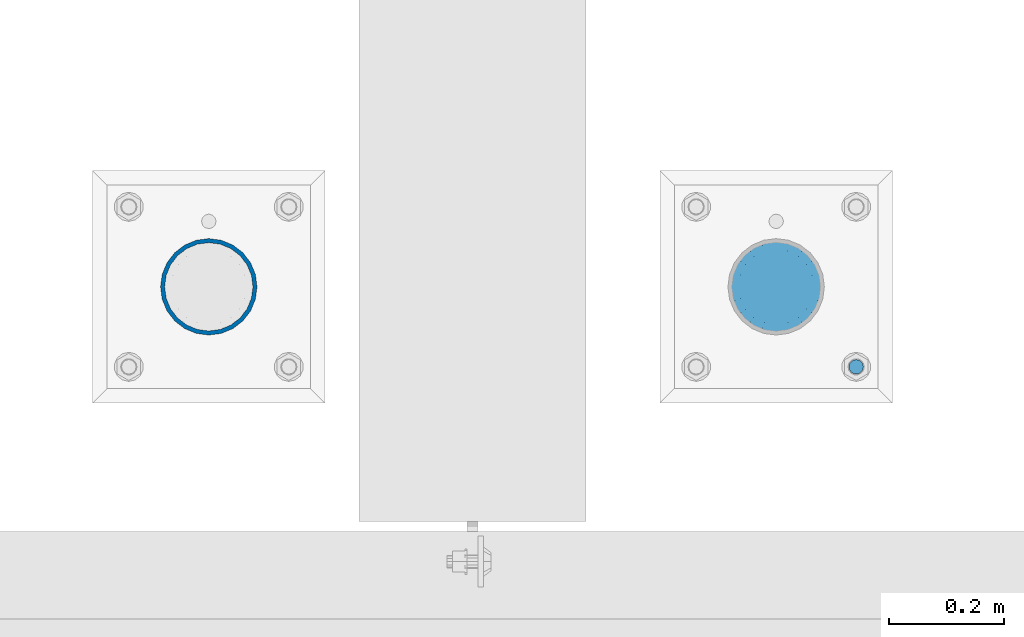
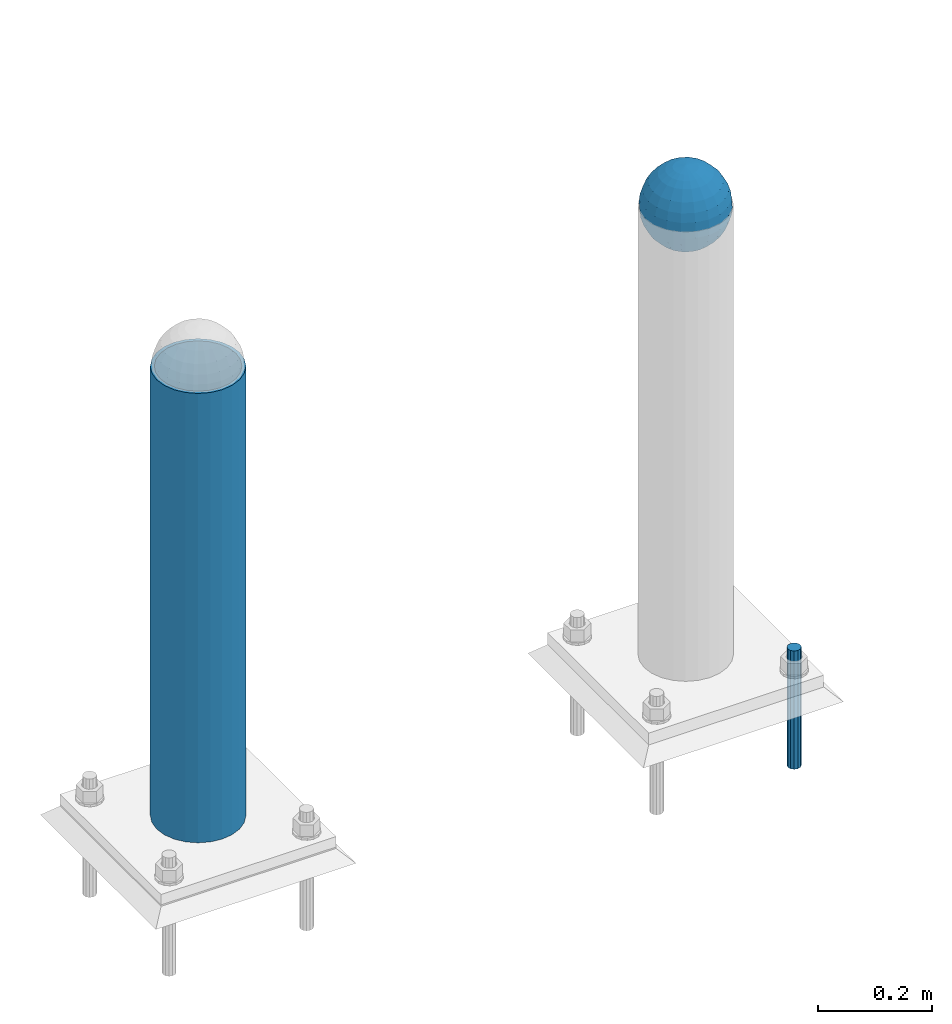
# One storey, part 1440 of 3843: 3 columns, 3 elements without a shape of their own.
"""IFC2X3 building model written with IfcOpenShell, lengths in millimetres."""

from ifc_helpers import new_model, si_unit, frame, origin_with_axes, place, context, subcontext, project, spatial, faceted_brep, material, type_object, element, aggregate, save


model = new_model("IFC2X3")

# Units and contexts
model_context = context("Model", 3, precision=1e-05, world=origin_with_axes())
body_context = subcontext(model_context, "Body", "Model", "MODEL_VIEW")
ifc_project = project(units=[si_unit("LENGTHUNIT", "METRE", prefix="MILLI"), si_unit("AREAUNIT", "SQUARE_METRE"), si_unit("VOLUMEUNIT", "CUBIC_METRE"), si_unit("MASSUNIT", "GRAM", prefix="KILO"), si_unit("TIMEUNIT", "SECOND"), si_unit("PLANEANGLEUNIT", "RADIAN"), si_unit("SOLIDANGLEUNIT", "STERADIAN"), si_unit("THERMODYNAMICTEMPERATUREUNIT", "DEGREE_CELSIUS"), si_unit("LUMINOUSINTENSITYUNIT", "LUMEN")], contexts=[model_context])

# Site, building, storey
site_placement = place(None, origin_with_axes())
site = spatial("IfcSite", under=ifc_project, at=site_placement, CompositionType="ELEMENT")
building_placement = place(site_placement, origin_with_axes())
building = spatial("IfcBuilding", under=site, at=building_placement, Name="Undefined", CompositionType="ELEMENT")
storey_placement = place(building_placement, origin_with_axes())
storey = spatial("IfcBuildingStorey", under=building, at=storey_placement, Name="Undefined", CompositionType="ELEMENT", Elevation=0.0)

# Assembly, column
assembly_1_placement = place(storey_placement, origin_with_axes())
assembly_1 = element("IfcElementAssembly", 1, at=assembly_1_placement, inside=storey, Name="CONC. FILL", AssemblyPlace="NOTDEFINED", PredefinedType="REINFORCEMENT_UNIT")
ifc_material_1 = material(Name="CONCRETE/1500")
column_type_1 = type_object("IfcColumnType", PredefinedType="NOTDEFINED")
column_1_placement = place(assembly_1_placement, frame((37106.2721557617, 11565.3447954918, 31411.8625), z_axis=(-1.0, 0.0, 0.0), x_axis=(0.0, 0.0, 1.0)))
column_1 = element("IfcColumn", 2, at=column_1_placement, type_object=column_type_1, material=ifc_material_1, Name="CONC. FILL", context=body_context, shape_type="Brep", body=[
    faceted_brep([(0.0, 0.0, 2.0), (0.0, -0.619999999995343, 1.89999999999964), (3.36549999999988, -7.1422259999963, 21.9814139999999), (3.36549999999988, 0.0, 23.1139999999996), (0.0, -1.17999999999302, 1.6200000000008), (3.36549999999988, -13.5910319999966, 18.6992260000006), (0.0, -1.61999999999534, 1.18000000000029), (3.36549999999988, -18.699225999997, 13.5910320000003), (0.0, -1.89999999999418, 0.6200000000008), (3.36549999999988, -21.9814139999944, 7.14222599999994), (0.0, -2.0, 0.0), (3.36549999999988, -23.1140000000014, 0.0), (0.0, -1.89999999999418, -0.6200000000008), (3.36549999999988, -21.9814139999944, -7.14222599999994), (0.0, -1.61999999999534, -1.18000000000029), (3.36549999999988, -18.699225999997, -13.5910320000003), (0.0, -1.17999999999302, -1.6200000000008), (3.36549999999988, -13.5910319999966, -18.6992260000006), (0.0, -0.619999999995343, -1.89999999999964), (3.36549999999988, -7.1422259999963, -21.9814139999999), (0.0, 0.0, -2.0), (3.36549999999988, 0.0, -23.1139999999996), (0.0, 0.619999999995343, -1.89999999999964), (3.36549999999988, 7.1422259999963, -21.9814139999999), (0.0, 1.17999999999302, -1.6200000000008), (3.36549999999988, 13.5910319999966, -18.6992260000006), (0.0, 1.61999999999534, -1.18000000000029), (3.36549999999988, 18.699225999997, -13.5910320000003), (0.0, 1.89999999999418, -0.6200000000008), (3.36549999999988, 21.9814139999944, -7.14222599999994), (0.0, 2.0, 0.0), (3.36549999999988, 23.1140000000014, 0.0), (0.0, 1.89999999999418, 0.6200000000008), (3.36549999999988, 21.9814139999944, 7.14222599999994), (0.0, 1.61999999999534, 1.18000000000029), (3.36549999999988, 18.699225999997, 13.5910320000003), (0.0, 1.17999999999302, 1.6200000000008), (3.36549999999988, 13.5910319999966, 18.6992260000006), (0.0, 0.619999999995343, 1.89999999999964), (3.36549999999988, 7.1422259999963, 21.9814139999999), (8.41374999999971, -11.1214661999984, 34.2282018000005), (8.41374999999971, 0.0, 35.9917999999998), (8.41374999999971, -21.1631784000056, 29.1173662000001), (8.41374999999971, -29.1173661999928, 21.1631784000001), (8.41374999999971, -34.2282017999969, 11.1214662000002), (8.41374999999971, -35.9918000000034, 0.0), (8.41374999999971, -34.2282017999969, -11.1214662000002), (8.41374999999971, -29.1173661999928, -21.1631784000001), (8.41374999999971, -21.1631784000056, -29.1173662000001), (8.41374999999971, -11.1214661999984, -34.2282018000005), (8.41374999999971, 0.0, -35.9917999999998), (8.41374999999971, 11.1214661999984, -34.2282018000005), (8.41374999999971, 21.1631784000056, -29.1173662000001), (8.41374999999971, 29.1173661999928, -21.1631784000001), (8.41374999999971, 34.2282017999969, -11.1214662000002), (8.41374999999971, 35.9918000000034, 0.0), (8.41374999999971, 34.2282017999969, 11.1214662000002), (8.41374999999971, 29.1173661999928, 21.1631784000001), (8.41374999999971, 21.1631784000056, 29.1173662000001), (8.41374999999971, 11.1214661999984, 34.2282018000005), (16.8274999999994, -15.3047700000025, 47.1030300000002), (16.8274999999994, 0.0, 49.5300000000007), (16.8274999999994, -29.1236400000053, 40.0697700000001), (16.8274999999994, -40.0697700000019, 29.1236399999998), (16.8274999999994, -47.1030299999984, 15.3047700000006), (16.8274999999994, -49.5299999999988, 0.0), (16.8274999999994, -47.1030299999984, -15.3047700000006), (16.8274999999994, -40.0697700000019, -29.1236399999998), (16.8274999999994, -29.1236400000053, -40.0697700000001), (16.8274999999994, -15.3047700000025, -47.1030300000002), (16.8274999999994, 0.0, -49.5300000000007), (16.8274999999994, 15.3047700000025, -47.1030300000002), (16.8274999999994, 29.1236400000053, -40.0697700000001), (16.8274999999994, 40.0697700000019, -29.1236399999998), (16.8274999999994, 47.1030299999984, -15.3047700000006), (16.8274999999994, 49.5299999999988, 0.0), (16.8274999999994, 47.1030299999984, 15.3047700000006), (16.8274999999994, 40.0697700000019, 29.1236399999998), (16.8274999999994, 29.1236400000053, 40.0697700000001), (16.8274999999994, 15.3047700000025, 47.1030300000002), (33.6549999999988, -20.4063599999936, 62.8040400000009), (33.6549999999988, 0.0, 66.0400000000009), (33.6549999999988, -38.831520000007, 53.4263599999995), (33.6549999999988, -53.4263599999977, 38.8315199999997), (33.6549999999988, -62.8040400000027, 20.4063600000009), (33.6549999999988, -66.0399999999936, 0.0), (33.6549999999988, -62.8040400000027, -20.4063600000009), (33.6549999999988, -53.4263599999977, -38.8315199999997), (33.6549999999988, -38.831520000007, -53.4263599999995), (33.6549999999988, -20.4063599999936, -62.8040400000009), (33.6549999999988, 0.0, -66.0400000000009), (33.6549999999988, 20.4063599999936, -62.8040400000009), (33.6549999999988, 38.831520000007, -53.4263599999995), (33.6549999999988, 53.4263599999977, -38.8315199999997), (33.6549999999988, 62.8040400000027, -20.4063600000009), (33.6549999999988, 66.0399999999936, 0.0), (33.6549999999988, 62.8040400000027, 20.4063600000009), (33.6549999999988, 53.4263599999977, 38.8315199999997), (33.6549999999988, 38.831520000007, 53.4263599999995), (33.6549999999988, 20.4063599999936, 62.8040400000009), (50.4824999999983, -23.3907901500061, 71.9891308499991), (50.4824999999983, 0.0, 75.6983500000006), (50.4824999999983, -44.5106298000028, 61.23996515), (50.4824999999983, -61.2399651500018, 44.5106297999992), (50.4824999999983, -71.9891308499937, 23.3907901500006), (50.4824999999983, -75.698350000006, 0.0), (50.4824999999983, -71.9891308499937, -23.3907901500006), (50.4824999999983, -61.2399651500018, -44.5106297999992), (50.4824999999983, -44.5106298000028, -61.23996515), (50.4824999999983, -23.3907901500061, -71.9891308499991), (50.4824999999983, 0.0, -75.6983500000006), (50.4824999999983, 23.3907901500061, -71.9891308499991), (50.4824999999983, 44.5106298000028, -61.23996515), (50.4824999999983, 61.2399651500018, -44.5106297999992), (50.4824999999983, 71.9891308499937, -23.3907901500006), (50.4824999999983, 75.698350000006, 0.0), (50.4824999999983, 71.9891308499937, 23.3907901500006), (50.4824999999983, 61.2399651500018, 44.5106297999992), (50.4824999999983, 44.5106298000028, 61.23996515), (50.4824999999983, 23.3907901500061, 71.9891308499991), (67.3099999999977, -24.9977910000016, 76.9349490000004), (67.3099999999977, 0.0, 80.8989999999994), (67.3099999999977, -47.5686120000028, 65.4472910000004), (67.3099999999977, -65.447291000004, 47.5686119999991), (67.3099999999977, -76.9349490000022, 24.9977909999998), (67.3099999999977, -80.8990000000049, 0.0), (67.3099999999977, -76.9349490000022, -24.9977909999998), (67.3099999999977, -65.447291000004, -47.5686119999991), (67.3099999999977, -47.5686120000028, -65.4472910000004), (67.3099999999977, -24.9977910000016, -76.9349490000004), (67.3099999999977, 0.0, -80.8989999999994), (67.3099999999977, 24.9977910000016, -76.9349490000004), (67.3099999999977, 47.5686120000028, -65.4472910000004), (67.3099999999977, 65.447291000004, -47.5686119999991), (67.3099999999977, 76.9349490000022, -24.9977909999998), (67.3099999999977, 80.8990000000049, 0.0), (67.3099999999977, 76.9349490000022, 24.9977909999998), (67.3099999999977, 65.447291000004, 47.5686119999991), (67.3099999999977, 47.5686120000028, 65.4472910000004), (67.3099999999977, 24.9977910000016, 76.9349490000004), (84.1374999999935, -25.5079499999993, 78.5050499999998), (84.1374999999935, 0.0, 82.5499999999993), (84.1374999999935, -48.5393999999942, 66.7829500000007), (84.1374999999935, -66.7829499999934, 48.5393999999997), (84.1374999999935, -78.505050000007, 25.5079499999993), (84.1374999999935, -82.5500000000029, 0.0), (84.1374999999935, -78.505050000007, -25.5079499999993), (84.1374999999935, -66.7829499999934, -48.5393999999997), (84.1374999999935, -48.5393999999942, -66.7829500000007), (84.1374999999935, -25.5079499999993, -78.5050499999998), (84.1374999999935, 0.0, -82.5499999999993), (84.1374999999935, 25.5079499999993, -78.5050499999998), (84.1374999999935, 48.5393999999942, -66.7829500000007), (84.1374999999935, 66.7829499999934, -48.5393999999997), (84.1374999999935, 78.505050000007, -25.5079499999993), (84.1374999999935, 82.5500000000029, 0.0), (84.1374999999935, 78.505050000007, 25.5079499999993), (84.1374999999935, 66.7829499999934, 48.5393999999997), (84.1374999999935, 48.5393999999942, 66.7829500000007), (84.1374999999935, 25.5079499999993, 78.5050499999998), (100.964999999993, -24.9977910000016, 76.9349490000004), (100.964999999993, 0.0, 80.8989999999994), (100.964999999993, -47.5686120000028, 65.4472910000004), (100.964999999993, -65.447291000004, 47.5686119999991), (100.964999999993, -76.9349490000022, 24.9977909999998), (100.964999999993, -80.8990000000049, 0.0), (100.964999999993, -76.9349490000022, -24.9977909999998), (100.964999999993, -65.447291000004, -47.5686119999991), (100.964999999993, -47.5686120000028, -65.4472910000004), (100.964999999993, -24.9977910000016, -76.9349490000004), (100.964999999993, 0.0, -80.8989999999994), (100.964999999993, 24.9977910000016, -76.9349490000004), (100.964999999993, 47.5686120000028, -65.4472910000004), (100.964999999993, 65.447291000004, -47.5686119999991), (100.964999999993, 76.9349490000022, -24.9977909999998), (100.964999999993, 80.8990000000049, 0.0), (100.964999999993, 76.9349490000022, 24.9977909999998), (100.964999999993, 65.447291000004, 47.5686119999991), (100.964999999993, 47.5686120000028, 65.4472910000004), (100.964999999993, 24.9977910000016, 76.9349490000004), (117.792499999992, -23.3907901500061, 71.9891308499991), (117.792499999992, 0.0, 75.6983500000006), (117.792499999992, -44.5106298000028, 61.23996515), (117.792499999992, -61.2399651500018, 44.5106297999992), (117.792499999992, -71.9891308499937, 23.3907901500006), (117.792499999992, -75.698350000006, 0.0), (117.792499999992, -71.9891308499937, -23.3907901500006), (117.792499999992, -61.2399651500018, -44.5106297999992), (117.792499999992, -44.5106298000028, -61.23996515), (117.792499999992, -23.3907901500061, -71.9891308499991), (117.792499999992, 0.0, -75.6983500000006), (117.792499999992, 23.3907901500061, -71.9891308499991), (117.792499999992, 44.5106298000028, -61.23996515), (117.792499999992, 61.2399651500018, -44.5106297999992), (117.792499999992, 71.9891308499937, -23.3907901500006), (117.792499999992, 75.698350000006, 0.0), (117.792499999992, 71.9891308499937, 23.3907901500006), (117.792499999992, 61.2399651500018, 44.5106297999992), (117.792499999992, 44.5106298000028, 61.23996515), (117.792499999992, 23.3907901500061, 71.9891308499991), (134.619999999992, -20.4063599999936, 62.8040400000009), (134.619999999992, 0.0, 66.0400000000009), (134.619999999992, -38.831520000007, 53.4263599999995), (134.619999999992, -53.4263599999977, 38.8315199999997), (134.619999999992, -62.8040400000027, 20.4063600000009), (134.619999999992, -66.0399999999936, 0.0), (134.619999999992, -62.8040400000027, -20.4063600000009), (134.619999999992, -53.4263599999977, -38.8315199999997), (134.619999999992, -38.831520000007, -53.4263599999995), (134.619999999992, -20.4063599999936, -62.8040400000009), (134.619999999992, 0.0, -66.0400000000009), (134.619999999992, 20.4063599999936, -62.8040400000009), (134.619999999992, 38.831520000007, -53.4263599999995), (134.619999999992, 53.4263599999977, -38.8315199999997), (134.619999999992, 62.8040400000027, -20.4063600000009), (134.619999999992, 66.0399999999936, 0.0), (134.619999999992, 62.8040400000027, 20.4063600000009), (134.619999999992, 53.4263599999977, 38.8315199999997), (134.619999999992, 38.831520000007, 53.4263599999995), (134.619999999992, 20.4063599999936, 62.8040400000009), (151.447499999991, -15.3047700000025, 47.1030300000002), (151.447499999991, 0.0, 49.5300000000007), (151.447499999991, -29.1236400000053, 40.0697700000001), (151.447499999991, -40.0697700000019, 29.1236399999998), (151.447499999991, -47.1030299999984, 15.3047700000006), (151.447499999991, -49.5299999999988, 0.0), (151.447499999991, -47.1030299999984, -15.3047700000006), (151.447499999991, -40.0697700000019, -29.1236399999998), (151.447499999991, -29.1236400000053, -40.0697700000001), (151.447499999991, -15.3047700000025, -47.1030300000002), (151.447499999991, 0.0, -49.5300000000007), (151.447499999991, 15.3047700000025, -47.1030300000002), (151.447499999991, 29.1236400000053, -40.0697700000001), (151.447499999991, 40.0697700000019, -29.1236399999998), (151.447499999991, 47.1030299999984, -15.3047700000006), (151.447499999991, 49.5299999999988, 0.0), (151.447499999991, 47.1030299999984, 15.3047700000006), (151.447499999991, 40.0697700000019, 29.1236399999998), (151.447499999991, 29.1236400000053, 40.0697700000001), (151.447499999991, 15.3047700000025, 47.1030300000002), (159.861249999991, -11.1214661999984, 34.2282018000005), (159.861249999991, 0.0, 35.9917999999998), (159.861249999991, -21.1631784000056, 29.1173662000001), (159.861249999991, -29.1173661999928, 21.1631784000001), (159.861249999991, -34.2282017999969, 11.1214662000002), (159.861249999991, -35.9918000000034, 0.0), (159.861249999991, -34.2282017999969, -11.1214662000002), (159.861249999991, -29.1173661999928, -21.1631784000001), (159.861249999991, -21.1631784000056, -29.1173662000001), (159.861249999991, -11.1214661999984, -34.2282018000005), (159.861249999991, 0.0, -35.9917999999998), (159.861249999991, 11.1214661999984, -34.2282018000005), (159.861249999991, 21.1631784000056, -29.1173662000001), (159.861249999991, 29.1173661999928, -21.1631784000001), (159.861249999991, 34.2282017999969, -11.1214662000002), (159.861249999991, 35.9918000000034, 0.0), (159.861249999991, 34.2282017999969, 11.1214662000002), (159.861249999991, 29.1173661999928, 21.1631784000001), (159.861249999991, 21.1631784000056, 29.1173662000001), (159.861249999991, 11.1214661999984, 34.2282018000005), (164.909499999991, -7.1422259999963, 21.9814139999999), (164.909499999991, 0.0, 23.1139999999996), (164.909499999991, -13.5910319999966, 18.6992260000006), (164.909499999991, -18.699225999997, 13.5910320000003), (164.909499999991, -21.9814139999944, 7.14222599999994), (164.909499999991, -23.1140000000014, 0.0), (164.909499999991, -21.9814139999944, -7.14222599999994), (164.909499999991, -18.699225999997, -13.5910320000003), (164.909499999991, -13.5910319999966, -18.6992260000006), (164.909499999991, -7.1422259999963, -21.9814139999999), (164.909499999991, 0.0, -23.1139999999996), (164.909499999991, 7.1422259999963, -21.9814139999999), (164.909499999991, 13.5910319999966, -18.6992260000006), (164.909499999991, 18.699225999997, -13.5910320000003), (164.909499999991, 21.9814139999944, -7.14222599999994), (164.909499999991, 23.1140000000014, 0.0), (164.909499999991, 21.9814139999944, 7.14222599999994), (164.909499999991, 18.699225999997, 13.5910320000003), (164.909499999991, 13.5910319999966, 18.6992260000006), (164.909499999991, 7.1422259999963, 21.9814139999999), (168.274999999991, -0.619999999995343, 1.89999999999964), (168.274999999991, 0.0, 2.0), (168.274999999991, -1.17999999999302, 1.6200000000008), (168.274999999991, -1.61999999999534, 1.18000000000029), (168.274999999991, -1.89999999999418, 0.6200000000008), (168.274999999991, -2.0, 0.0), (168.274999999991, -1.89999999999418, -0.6200000000008), (168.274999999991, -1.61999999999534, -1.18000000000029), (168.274999999991, -1.17999999999302, -1.6200000000008), (168.274999999991, -0.619999999995343, -1.89999999999964), (168.274999999991, 0.0, -2.0), (168.274999999991, 0.619999999995343, -1.89999999999964), (168.274999999991, 1.17999999999302, -1.6200000000008), (168.274999999991, 1.61999999999534, -1.18000000000029), (168.274999999991, 1.89999999999418, -0.6200000000008), (168.274999999991, 2.0, 0.0), (168.274999999991, 1.89999999999418, 0.6200000000008), (168.274999999991, 1.61999999999534, 1.18000000000029), (168.274999999991, 1.17999999999302, 1.6200000000008), (168.274999999991, 0.619999999995343, 1.89999999999964)], [[[0, 1, 2, 3]], [[1, 4, 5, 2]], [[4, 6, 7, 5]], [[6, 8, 9, 7]], [[8, 10, 11, 9]], [[10, 12, 13, 11]], [[12, 14, 15, 13]], [[14, 16, 17, 15]], [[16, 18, 19, 17]], [[18, 20, 21, 19]], [[20, 22, 23, 21]], [[22, 24, 25, 23]], [[24, 26, 27, 25]], [[26, 28, 29, 27]], [[28, 30, 31, 29]], [[30, 32, 33, 31]], [[32, 34, 35, 33]], [[34, 36, 37, 35]], [[36, 38, 39, 37]], [[38, 0, 3, 39]], [[38, 36, 34, 32, 30, 28, 26, 24, 22, 20, 18, 16, 14, 12, 10, 8, 6, 4, 1, 0]], [[3, 2, 40, 41]], [[2, 5, 42, 40]], [[5, 7, 43, 42]], [[7, 9, 44, 43]], [[9, 11, 45, 44]], [[11, 13, 46, 45]], [[13, 15, 47, 46]], [[15, 17, 48, 47]], [[17, 19, 49, 48]], [[19, 21, 50, 49]], [[21, 23, 51, 50]], [[23, 25, 52, 51]], [[25, 27, 53, 52]], [[27, 29, 54, 53]], [[29, 31, 55, 54]], [[31, 33, 56, 55]], [[33, 35, 57, 56]], [[35, 37, 58, 57]], [[37, 39, 59, 58]], [[39, 3, 41, 59]], [[41, 40, 60, 61]], [[40, 42, 62, 60]], [[42, 43, 63, 62]], [[43, 44, 64, 63]], [[44, 45, 65, 64]], [[45, 46, 66, 65]], [[46, 47, 67, 66]], [[47, 48, 68, 67]], [[48, 49, 69, 68]], [[49, 50, 70, 69]], [[50, 51, 71, 70]], [[51, 52, 72, 71]], [[52, 53, 73, 72]], [[53, 54, 74, 73]], [[54, 55, 75, 74]], [[55, 56, 76, 75]], [[56, 57, 77, 76]], [[57, 58, 78, 77]], [[58, 59, 79, 78]], [[59, 41, 61, 79]], [[61, 60, 80, 81]], [[60, 62, 82, 80]], [[62, 63, 83, 82]], [[63, 64, 84, 83]], [[64, 65, 85, 84]], [[65, 66, 86, 85]], [[66, 67, 87, 86]], [[67, 68, 88, 87]], [[68, 69, 89, 88]], [[69, 70, 90, 89]], [[70, 71, 91, 90]], [[71, 72, 92, 91]], [[72, 73, 93, 92]], [[73, 74, 94, 93]], [[74, 75, 95, 94]], [[75, 76, 96, 95]], [[76, 77, 97, 96]], [[77, 78, 98, 97]], [[78, 79, 99, 98]], [[79, 61, 81, 99]], [[81, 80, 100, 101]], [[80, 82, 102, 100]], [[82, 83, 103, 102]], [[83, 84, 104, 103]], [[84, 85, 105, 104]], [[85, 86, 106, 105]], [[86, 87, 107, 106]], [[87, 88, 108, 107]], [[88, 89, 109, 108]], [[89, 90, 110, 109]], [[90, 91, 111, 110]], [[91, 92, 112, 111]], [[92, 93, 113, 112]], [[93, 94, 114, 113]], [[94, 95, 115, 114]], [[95, 96, 116, 115]], [[96, 97, 117, 116]], [[97, 98, 118, 117]], [[98, 99, 119, 118]], [[99, 81, 101, 119]], [[101, 100, 120, 121]], [[100, 102, 122, 120]], [[102, 103, 123, 122]], [[103, 104, 124, 123]], [[104, 105, 125, 124]], [[105, 106, 126, 125]], [[106, 107, 127, 126]], [[107, 108, 128, 127]], [[108, 109, 129, 128]], [[109, 110, 130, 129]], [[110, 111, 131, 130]], [[111, 112, 132, 131]], [[112, 113, 133, 132]], [[113, 114, 134, 133]], [[114, 115, 135, 134]], [[115, 116, 136, 135]], [[116, 117, 137, 136]], [[117, 118, 138, 137]], [[118, 119, 139, 138]], [[119, 101, 121, 139]], [[121, 120, 140, 141]], [[120, 122, 142, 140]], [[122, 123, 143, 142]], [[123, 124, 144, 143]], [[124, 125, 145, 144]], [[125, 126, 146, 145]], [[126, 127, 147, 146]], [[127, 128, 148, 147]], [[128, 129, 149, 148]], [[129, 130, 150, 149]], [[130, 131, 151, 150]], [[131, 132, 152, 151]], [[132, 133, 153, 152]], [[133, 134, 154, 153]], [[134, 135, 155, 154]], [[135, 136, 156, 155]], [[136, 137, 157, 156]], [[137, 138, 158, 157]], [[138, 139, 159, 158]], [[139, 121, 141, 159]], [[141, 140, 160, 161]], [[140, 142, 162, 160]], [[142, 143, 163, 162]], [[143, 144, 164, 163]], [[144, 145, 165, 164]], [[145, 146, 166, 165]], [[146, 147, 167, 166]], [[147, 148, 168, 167]], [[148, 149, 169, 168]], [[149, 150, 170, 169]], [[150, 151, 171, 170]], [[151, 152, 172, 171]], [[152, 153, 173, 172]], [[153, 154, 174, 173]], [[154, 155, 175, 174]], [[155, 156, 176, 175]], [[156, 157, 177, 176]], [[157, 158, 178, 177]], [[158, 159, 179, 178]], [[159, 141, 161, 179]], [[161, 160, 180, 181]], [[160, 162, 182, 180]], [[162, 163, 183, 182]], [[163, 164, 184, 183]], [[164, 165, 185, 184]], [[165, 166, 186, 185]], [[166, 167, 187, 186]], [[167, 168, 188, 187]], [[168, 169, 189, 188]], [[169, 170, 190, 189]], [[170, 171, 191, 190]], [[171, 172, 192, 191]], [[172, 173, 193, 192]], [[173, 174, 194, 193]], [[174, 175, 195, 194]], [[175, 176, 196, 195]], [[176, 177, 197, 196]], [[177, 178, 198, 197]], [[178, 179, 199, 198]], [[179, 161, 181, 199]], [[181, 180, 200, 201]], [[180, 182, 202, 200]], [[182, 183, 203, 202]], [[183, 184, 204, 203]], [[184, 185, 205, 204]], [[185, 186, 206, 205]], [[186, 187, 207, 206]], [[187, 188, 208, 207]], [[188, 189, 209, 208]], [[189, 190, 210, 209]], [[190, 191, 211, 210]], [[191, 192, 212, 211]], [[192, 193, 213, 212]], [[193, 194, 214, 213]], [[194, 195, 215, 214]], [[195, 196, 216, 215]], [[196, 197, 217, 216]], [[197, 198, 218, 217]], [[198, 199, 219, 218]], [[199, 181, 201, 219]], [[201, 200, 220, 221]], [[200, 202, 222, 220]], [[202, 203, 223, 222]], [[203, 204, 224, 223]], [[204, 205, 225, 224]], [[205, 206, 226, 225]], [[206, 207, 227, 226]], [[207, 208, 228, 227]], [[208, 209, 229, 228]], [[209, 210, 230, 229]], [[210, 211, 231, 230]], [[211, 212, 232, 231]], [[212, 213, 233, 232]], [[213, 214, 234, 233]], [[214, 215, 235, 234]], [[215, 216, 236, 235]], [[216, 217, 237, 236]], [[217, 218, 238, 237]], [[218, 219, 239, 238]], [[219, 201, 221, 239]], [[221, 220, 240, 241]], [[220, 222, 242, 240]], [[222, 223, 243, 242]], [[223, 224, 244, 243]], [[224, 225, 245, 244]], [[225, 226, 246, 245]], [[226, 227, 247, 246]], [[227, 228, 248, 247]], [[228, 229, 249, 248]], [[229, 230, 250, 249]], [[230, 231, 251, 250]], [[231, 232, 252, 251]], [[232, 233, 253, 252]], [[233, 234, 254, 253]], [[234, 235, 255, 254]], [[235, 236, 256, 255]], [[236, 237, 257, 256]], [[237, 238, 258, 257]], [[238, 239, 259, 258]], [[239, 221, 241, 259]], [[241, 240, 260, 261]], [[240, 242, 262, 260]], [[242, 243, 263, 262]], [[243, 244, 264, 263]], [[244, 245, 265, 264]], [[245, 246, 266, 265]], [[246, 247, 267, 266]], [[247, 248, 268, 267]], [[248, 249, 269, 268]], [[249, 250, 270, 269]], [[250, 251, 271, 270]], [[251, 252, 272, 271]], [[252, 253, 273, 272]], [[253, 254, 274, 273]], [[254, 255, 275, 274]], [[255, 256, 276, 275]], [[256, 257, 277, 276]], [[257, 258, 278, 277]], [[258, 259, 279, 278]], [[259, 241, 261, 279]], [[261, 260, 280, 281]], [[260, 262, 282, 280]], [[262, 263, 283, 282]], [[263, 264, 284, 283]], [[264, 265, 285, 284]], [[265, 266, 286, 285]], [[266, 267, 287, 286]], [[267, 268, 288, 287]], [[268, 269, 289, 288]], [[269, 270, 290, 289]], [[270, 271, 291, 290]], [[271, 272, 292, 291]], [[272, 273, 293, 292]], [[273, 274, 294, 293]], [[274, 275, 295, 294]], [[275, 276, 296, 295]], [[276, 277, 297, 296]], [[277, 278, 298, 297]], [[278, 279, 299, 298]], [[279, 261, 281, 299]], [[282, 283, 284, 285, 286, 287, 288, 289, 290, 291, 292, 293, 294, 295, 296, 297, 298, 299, 281, 280]]]),
])
aggregate(assembly_1, [column_1])

assembly_2_placement = place(storey_placement, origin_with_axes())
assembly_2 = element("IfcElementAssembly", 3, at=assembly_2_placement, inside=storey, Name="PIPE_BOLLARD", AssemblyPlace="NOTDEFINED", PredefinedType="RIGID_FRAME")
ifc_material_2 = material()
column_type_2 = type_object("IfcColumnType", Name="PIPE6SCH40", PredefinedType="NOTDEFINED")
column_2_placement = place(assembly_2_placement, frame((36115.6715698242, 11565.3447954918, 30480.0), z_axis=(-1.0, 0.0, 0.0), x_axis=(0.0, 0.0, 1.0)))
column_2 = element("IfcColumn", 4, at=column_2_placement, type_object=column_type_2, material=ifc_material_2, Name="PIPE_BOLLARD", ObjectType="PIPE6SCH40", context=body_context, shape_type="Brep", body=[
    faceted_brep([(50.7999999999993, -77.0890000000072, 0.0), (50.7999999999993, -74.4622560228017, 19.9521013679114), (1016.0, -74.4622560228017, 19.9521013679114), (1016.0, -77.0890000000072, 0.0), (50.7999999999993, -66.7610323523404, 38.5445000000036), (1016.0, -66.7610323523404, 38.5445000000036), (50.7999999999993, -54.5101546548831, 54.5101546548904), (1016.0, -54.5101546548831, 54.5101546548904), (50.7999999999993, -38.5445000000036, 66.7610323523404), (1016.0, -38.5445000000036, 66.7610323523404), (50.7999999999993, -19.9521013679041, 74.4622560227945), (1016.0, -19.9521013679041, 74.4622560227945), (50.7999999999993, 0.0, 77.0889999999999), (1016.0, 0.0, 77.0889999999999), (50.7999999999993, 19.9521013679041, 74.4622560227945), (1016.0, 19.9521013679041, 74.4622560227945), (50.7999999999993, 38.5445000000036, 66.7610323523404), (1016.0, 38.5445000000036, 66.7610323523404), (50.7999999999993, 54.5101546548831, 54.5101546548904), (1016.0, 54.5101546548831, 54.5101546548904), (50.7999999999993, 66.7610323523404, 38.5445000000036), (1016.0, 66.7610323523404, 38.5445000000036), (50.7999999999993, 74.4622560228017, 19.9521013679114), (1016.0, 74.4622560228017, 19.9521013679114), (50.7999999999993, 77.0890000000072, 0.0), (1016.0, 77.0890000000072, 0.0), (50.7999999999993, 74.4622560228017, -19.9521013679114), (1016.0, 74.4622560228017, -19.9521013679114), (50.7999999999993, 66.7610323523404, -38.5445000000036), (1016.0, 66.7610323523404, -38.5445000000036), (50.7999999999993, 54.5101546548831, -54.5101546548904), (1016.0, 54.5101546548831, -54.5101546548904), (50.7999999999993, 38.5445000000036, -66.7610323523404), (1016.0, 38.5445000000036, -66.7610323523404), (50.7999999999993, 19.9521013679041, -74.4622560227945), (1016.0, 19.9521013679041, -74.4622560227945), (50.7999999999993, 0.0, -77.0889999999999), (1016.0, 0.0, -77.0889999999999), (50.7999999999993, -19.9521013679041, -74.4622560227945), (1016.0, -19.9521013679041, -74.4622560227945), (50.7999999999993, -38.5445000000036, -66.7610323523404), (1016.0, -38.5445000000036, -66.7610323523404), (50.7999999999993, -54.5101546548831, -54.5101546548904), (1016.0, -54.5101546548831, -54.5101546548904), (50.7999999999993, -66.7610323523404, -38.5445000000036), (1016.0, -66.7610323523404, -38.5445000000036), (50.7999999999993, -74.4622560228017, -19.9521013679114), (1016.0, -74.4622560228017, -19.9521013679114), (50.7999999999993, -84.2010000000009, 0.0), (50.7999999999993, -81.3319204993604, -21.7928224166753), (1016.0, -81.3319204993604, -21.7928224166753), (1016.0, -84.2010000000009, 0.0), (50.7999999999993, -72.9202050240565, -42.1005000000005), (1016.0, -72.9202050240565, -42.1005000000005), (50.7999999999993, -59.5390980826924, -59.5390980826851), (1016.0, -59.5390980826924, -59.5390980826851), (50.7999999999993, -42.1005000000005, -72.9202050240565), (1016.0, -42.1005000000005, -72.9202050240565), (50.7999999999993, -21.7928224166826, -81.3319204993677), (1016.0, -21.7928224166826, -81.3319204993677), (50.7999999999993, 0.0, -84.2010000000009), (1016.0, 0.0, -84.2010000000009), (50.7999999999993, 21.7928224166826, -81.3319204993677), (1016.0, 21.7928224166826, -81.3319204993677), (50.7999999999993, 42.1005000000005, -72.9202050240565), (1016.0, 42.1005000000005, -72.9202050240565), (50.7999999999993, 59.5390980826924, -59.5390980826851), (1016.0, 59.5390980826924, -59.5390980826851), (50.7999999999993, 72.9202050240565, -42.1005000000005), (1016.0, 72.9202050240565, -42.1005000000005), (50.7999999999993, 81.3319204993604, -21.7928224166753), (1016.0, 81.3319204993604, -21.7928224166753), (50.7999999999993, 84.2010000000009, 0.0), (1016.0, 84.2010000000009, 0.0), (50.7999999999993, 81.3319204993604, 21.7928224166753), (1016.0, 81.3319204993604, 21.7928224166753), (50.7999999999993, 72.9202050240565, 42.1005000000005), (1016.0, 72.9202050240565, 42.1005000000005), (50.7999999999993, 59.5390980826924, 59.5390980826851), (1016.0, 59.5390980826924, 59.5390980826851), (50.7999999999993, 42.1005000000005, 72.9202050240565), (1016.0, 42.1005000000005, 72.9202050240565), (50.7999999999993, 21.7928224166826, 81.3319204993677), (1016.0, 21.7928224166826, 81.3319204993677), (50.7999999999993, 0.0, 84.2010000000009), (1016.0, 0.0, 84.2010000000009), (50.7999999999993, -21.7928224166826, 81.3319204993677), (1016.0, -21.7928224166826, 81.3319204993677), (50.7999999999993, -42.1005000000005, 72.9202050240565), (1016.0, -42.1005000000005, 72.9202050240565), (50.7999999999993, -59.5390980826924, 59.5390980826851), (1016.0, -59.5390980826924, 59.5390980826851), (50.7999999999993, -72.9202050240565, 42.1005000000005), (1016.0, -72.9202050240565, 42.1005000000005), (50.7999999999993, -81.3319204993604, 21.7928224166753), (1016.0, -81.3319204993604, 21.7928224166753)], [[[0, 1, 2, 3]], [[1, 4, 5, 2]], [[4, 6, 7, 5]], [[6, 8, 9, 7]], [[8, 10, 11, 9]], [[10, 12, 13, 11]], [[12, 14, 15, 13]], [[14, 16, 17, 15]], [[16, 18, 19, 17]], [[18, 20, 21, 19]], [[20, 22, 23, 21]], [[22, 24, 25, 23]], [[24, 26, 27, 25]], [[26, 28, 29, 27]], [[28, 30, 31, 29]], [[30, 32, 33, 31]], [[32, 34, 35, 33]], [[34, 36, 37, 35]], [[36, 38, 39, 37]], [[38, 40, 41, 39]], [[40, 42, 43, 41]], [[42, 44, 45, 43]], [[44, 46, 47, 45]], [[46, 0, 3, 47]], [[48, 49, 50, 51]], [[49, 52, 53, 50]], [[52, 54, 55, 53]], [[54, 56, 57, 55]], [[56, 58, 59, 57]], [[58, 60, 61, 59]], [[60, 62, 63, 61]], [[62, 64, 65, 63]], [[64, 66, 67, 65]], [[66, 68, 69, 67]], [[68, 70, 71, 69]], [[70, 72, 73, 71]], [[72, 74, 75, 73]], [[74, 76, 77, 75]], [[76, 78, 79, 77]], [[78, 80, 81, 79]], [[80, 82, 83, 81]], [[82, 84, 85, 83]], [[84, 86, 87, 85]], [[86, 88, 89, 87]], [[88, 90, 91, 89]], [[90, 92, 93, 91]], [[92, 94, 95, 93]], [[94, 48, 51, 95]], [[53, 55, 57, 59, 61, 63, 65, 67, 69, 71, 73, 75, 77, 79, 81, 83, 85, 87, 89, 91, 93, 95, 51, 50], [5, 7, 9, 11, 13, 15, 17, 19, 21, 23, 25, 27, 29, 31, 33, 35, 37, 39, 41, 43, 45, 47, 3, 2]], [[94, 92, 90, 88, 86, 84, 82, 80, 78, 76, 74, 72, 70, 68, 66, 64, 62, 60, 58, 56, 54, 52, 49, 48], [46, 44, 42, 40, 38, 36, 34, 32, 30, 28, 26, 24, 22, 20, 18, 16, 14, 12, 10, 8, 6, 4, 1, 0]]]),
])
aggregate(assembly_2, [column_2])

assembly_3_placement = place(storey_placement, origin_with_axes())
assembly_3 = element("IfcElementAssembly", 5, at=assembly_3_placement, inside=storey, Name="TEMPLATE", AssemblyPlace="NOTDEFINED", PredefinedType="RIGID_FRAME")
ifc_material_3 = material(Name="STEEL/316 SS")
column_type_3 = type_object("IfcColumnType", PredefinedType="NOTDEFINED")
column_3_placement = place(assembly_3_placement, frame((37245.9721557617, 11425.6447954918, 30581.6), z_axis=(1.0, 0.0, 0.0), x_axis=(0.0, 0.0, -1.0)))
column_3 = element("IfcColumn", 6, at=column_3_placement, type_object=column_type_3, material=ifc_material_3, Name="ANCHOR_ROD", context=body_context, shape_type="Brep", body=[
    faceted_brep([(0.0, -12.6999999999971, 0.0), (0.0, -10.9985226280696, -6.34999999999854), (253.999, -10.9985226280696, -6.34999999999854), (253.999, -12.6999999999971, 0.0), (0.0, -6.35000000000582, -10.9985226280623), (253.999, -6.35000000000582, -10.9985226280623), (0.0, 0.0, -12.6999999999971), (253.999, 0.0, -12.6999999999971), (0.0, 6.35000000000582, -10.9985226280623), (253.999, 6.35000000000582, -10.9985226280623), (0.0, 10.9985226280696, -6.34999999999854), (253.999, 10.9985226280696, -6.34999999999854), (0.0, 12.6999999999971, 0.0), (253.999, 12.6999999999971, 0.0), (0.0, 10.9985226280696, 6.34999999999854), (253.999, 10.9985226280696, 6.34999999999854), (0.0, 6.35000000000582, 10.9985226280623), (253.999, 6.35000000000582, 10.9985226280623), (0.0, 0.0, 12.6999999999971), (253.999, 0.0, 12.6999999999971), (0.0, -6.35000000000582, 10.9985226280623), (253.999, -6.35000000000582, 10.9985226280623), (0.0, -10.9985226280696, 6.34999999999854), (253.999, -10.9985226280696, 6.34999999999854)], [[[0, 1, 2, 3]], [[1, 4, 5, 2]], [[4, 6, 7, 5]], [[6, 8, 9, 7]], [[8, 10, 11, 9]], [[10, 12, 13, 11]], [[12, 14, 15, 13]], [[14, 16, 17, 15]], [[16, 18, 19, 17]], [[18, 20, 21, 19]], [[20, 22, 23, 21]], [[22, 0, 3, 23]], [[5, 7, 9, 11, 13, 15, 17, 19, 21, 23, 3, 2]], [[22, 20, 18, 16, 14, 12, 10, 8, 6, 4, 1, 0]]]),
])
aggregate(assembly_3, [column_3])

save(model, "model.ifc")
